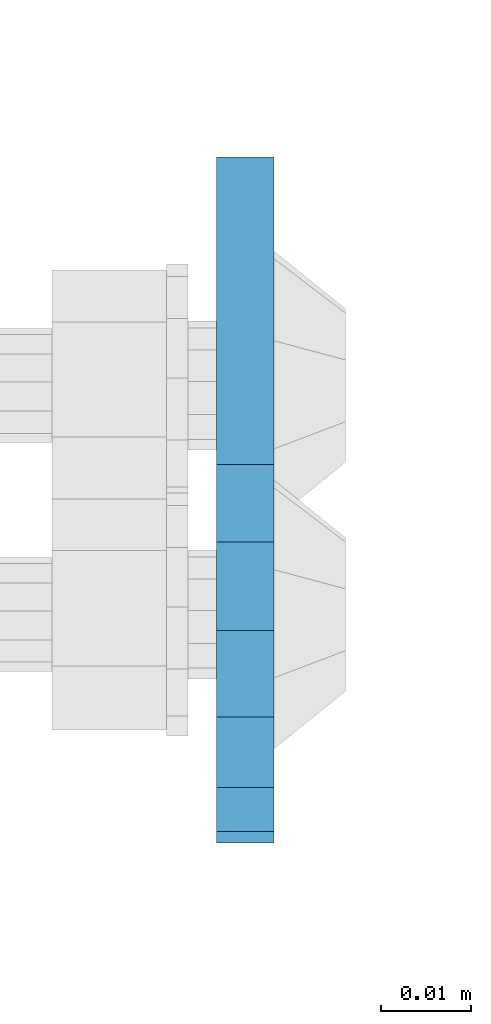
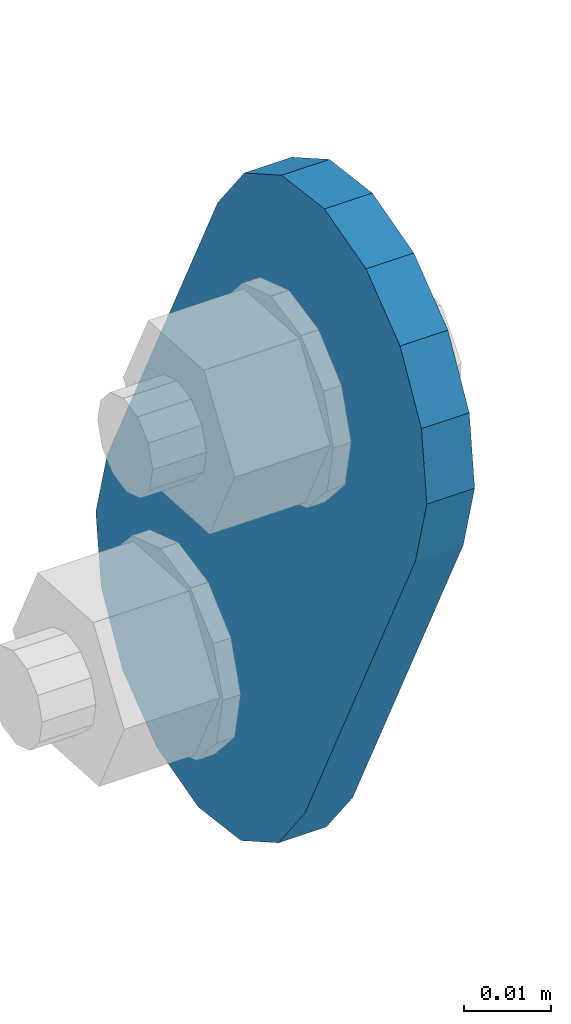
# One storey, part 1831 of 1876: 1 plate, 1 element without a shape of its own.
"""IFC2X3 building model written with IfcOpenShell, lengths in millimetres."""

from ifc_helpers import new_model, si_unit, frame, origin_with_axes, place, context, subcontext, project, spatial, faceted_brep, material, type_object, element, aggregate, save


model = new_model("IFC2X3")

# Units and contexts
model_context = context("Model", 3, precision=1e-05, world=origin_with_axes())
body_context = subcontext(model_context, "Body", "Model", "MODEL_VIEW")
ifc_project = project(units=[si_unit("LENGTHUNIT", "METRE", prefix="MILLI"), si_unit("AREAUNIT", "SQUARE_METRE"), si_unit("VOLUMEUNIT", "CUBIC_METRE"), si_unit("MASSUNIT", "GRAM", prefix="KILO"), si_unit("TIMEUNIT", "SECOND"), si_unit("PLANEANGLEUNIT", "RADIAN"), si_unit("SOLIDANGLEUNIT", "STERADIAN"), si_unit("THERMODYNAMICTEMPERATUREUNIT", "DEGREE_CELSIUS"), si_unit("LUMINOUSINTENSITYUNIT", "LUMEN")], contexts=[model_context])

# Site, building, storey
site_placement = place(None, origin_with_axes())
site = spatial("IfcSite", under=ifc_project, at=site_placement, CompositionType="ELEMENT")
building_placement = place(site_placement, origin_with_axes())
building = spatial("IfcBuilding", under=site, at=building_placement, Name="Undefined", CompositionType="ELEMENT")
storey_placement = place(building_placement, origin_with_axes())
storey = spatial("IfcBuildingStorey", under=building, at=storey_placement, Name="Undefined", CompositionType="ELEMENT", Elevation=0.0)

# Assembly, plate
assembly_placement = place(storey_placement, origin_with_axes())
assembly = element("IfcElementAssembly", 1, at=assembly_placement, inside=storey, Name="PLATE", AssemblyPlace="NOTDEFINED", PredefinedType="RIGID_FRAME")
ifc_material = material(Name="STEEL/A36")
plate_type = type_object("IfcPlateType", PredefinedType="NOTDEFINED")
plate_placement = place(assembly_placement, frame((-400.038795215646, 14070.1626500628, 7895.37767748095), z_axis=(0.0, -0.894427191199917, -0.447213595099956), x_axis=(0.0, 0.447213595099955, -0.894427191199917)))
plate = element("IfcPlate", 2, at=plate_placement, type_object=plate_type, material=ifc_material, Name="PLATE", context=body_context, shape_type="Brep", body=[
    faceted_brep([(-8.59611645864788e-07, -3.17499999999654, 25.3999987589127), (1.93345873884391, -3.17499999999382, 35.1201580589886), (1.93345873884391, 3.17500000000564, 35.1201580589886), (-8.59611645864788e-07, 3.17500000000382, 25.3999987589132), (7.43948648259902, -3.17499999999109, 43.3605112870105), (7.43948648259902, 3.17500000000928, 43.3605112870105), (15.6798395242777, -3.17499999998654, 48.8665393096448), (15.6798395242777, 3.17500000001382, 48.8665393096448), (25.3999987589095, -3.17499999998199, 50.7999992370592), (25.3999987589095, 3.17500000001837, 50.7999992370592), (82.196130752618, -3.17499999998381, 50.7999992370605), (82.196130752618, 3.17500000001655, 50.7999992370642), (91.9162897887145, -3.17499999997926, 48.8665393918873), (91.9162897887145, 3.1750000000211, 48.8665393918909), (100.156642725027, -3.17499999997472, 43.3605115909359), (100.156642725027, 3.17500000002565, 43.3605115909395), (105.662670525982, -3.17499999997108, 35.1201586546285), (105.662670525986, 3.17500000002929, 35.1201586546358), (107.596130371159, -3.17499999996744, 25.3999996185757), (107.596130371159, 3.17500000003292, 25.3999996185794), (105.662670525981, -3.17499999996471, 15.6798405824902), (105.662670525981, 3.17500000003565, 15.6798405824939), (100.156642725024, -3.17499999996471, 7.43948764618654), (100.156642725025, 3.17500000003565, 7.43948764619017), (91.9162897887127, -3.17499999996562, 1.93345984522784), (91.9162897887127, 3.17500000003474, 1.93345984523148), (82.196130752618, -3.17499999996835, 4.54747350886464e-11), (82.196130752618, 3.1750000000311, 4.91127138957381e-11), (25.399998758905, -3.17499999999018, -8.64019966684282e-12), (25.399998758905, 3.17500000001019, -8.64019966684282e-12), (15.679839921364, -3.17499999999382, 1.9334597629304), (15.679839921364, 3.17500000000655, 1.9334597629304), (7.43948709043525, -3.17499999999654, 7.43948734220839), (7.43948709043525, 3.17500000000382, 7.43948734220885), (1.93345923228208, -3.17499999999654, 15.6798399868012), (1.93345923228208, 3.17500000000291, 15.6798399868012)], [[[0, 1, 2, 3]], [[1, 4, 5, 2]], [[4, 6, 7, 5]], [[6, 8, 9, 7]], [[8, 10, 11, 9]], [[10, 12, 13, 11]], [[12, 14, 15, 13]], [[14, 16, 17, 15]], [[16, 18, 19, 17]], [[18, 20, 21, 19]], [[20, 22, 23, 21]], [[22, 24, 25, 23]], [[24, 26, 27, 25]], [[26, 28, 29, 27]], [[28, 30, 31, 29]], [[30, 32, 33, 31]], [[32, 34, 35, 33]], [[34, 0, 3, 35]], [[5, 7, 9, 11, 13, 15, 17, 19, 21, 23, 25, 27, 29, 31, 33, 35, 3, 2]], [[34, 32, 30, 28, 26, 24, 22, 20, 18, 16, 14, 12, 10, 8, 6, 4, 1, 0]]]),
])
aggregate(assembly, [plate])

save(model, "model.ifc")
